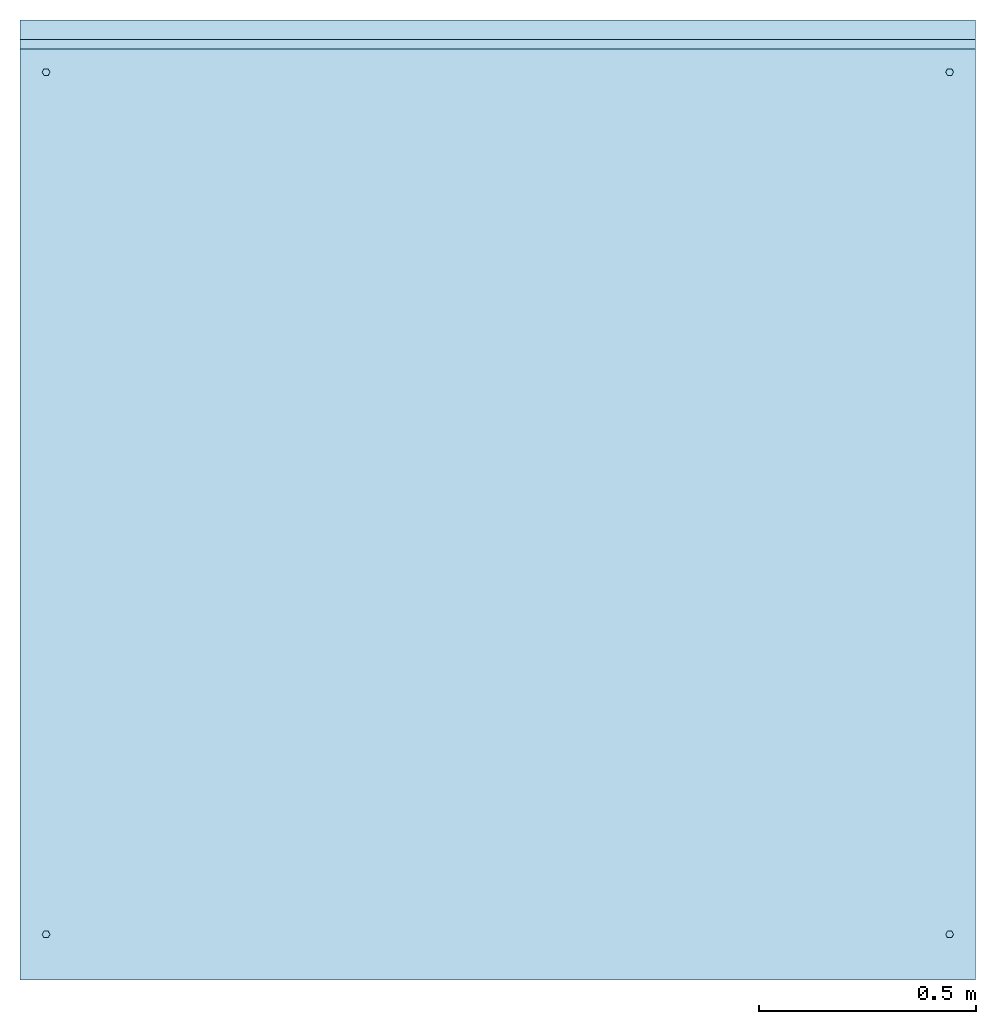
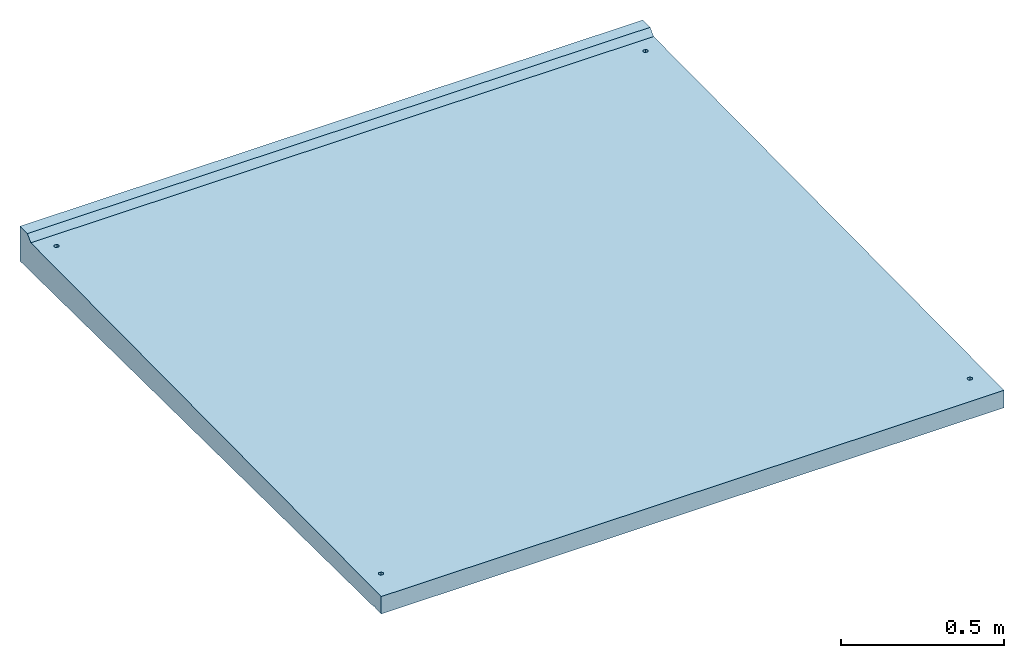
# One storey: 1 slab.
"""IFC2X3 building model written with IfcOpenShell, lengths in millimetres."""

from ifc_helpers import new_model, entity, si_unit, converted_unit, derived_unit, direction, frame, origin, place, context, subcontext, project, spatial, faceted_brep, material, type_object, element, save


model = new_model("IFC2X3")

# Units and contexts
model_context = context("Model", 3, precision=0.01, world=origin(), true_north=direction((6.12303176911189e-17, 1.0)))
body_context = subcontext(model_context, "Body", "Model", "MODEL_VIEW")
ifc_project = project(units=[si_unit("LENGTHUNIT", "METRE", prefix="MILLI"), si_unit("AREAUNIT", "SQUARE_METRE"), si_unit("VOLUMEUNIT", "CUBIC_METRE"), converted_unit("PLANEANGLEUNIT", "DEGREE", entity("IfcRatioMeasure", 0.0174532925199433), si_unit("PLANEANGLEUNIT", "RADIAN"), dimensions=[0, 0, 0, 0, 0, 0, 0]), si_unit("MASSUNIT", "GRAM", prefix="KILO"), derived_unit("MASSDENSITYUNIT", [(si_unit("MASSUNIT", "GRAM", prefix="KILO"), 1), (si_unit("LENGTHUNIT", "METRE"), -3)]), derived_unit("MOMENTOFINERTIAUNIT", [(si_unit("LENGTHUNIT", "METRE"), 4)]), si_unit("TIMEUNIT", "SECOND"), si_unit("FREQUENCYUNIT", "HERTZ"), si_unit("THERMODYNAMICTEMPERATUREUNIT", "DEGREE_CELSIUS"), derived_unit("THERMALTRANSMITTANCEUNIT", [(si_unit("MASSUNIT", "GRAM", prefix="KILO"), 1), (si_unit("THERMODYNAMICTEMPERATUREUNIT", "KELVIN"), -1), (si_unit("TIMEUNIT", "SECOND"), -3)]), derived_unit("VOLUMETRICFLOWRATEUNIT", [(si_unit("LENGTHUNIT", "METRE"), 3), (si_unit("TIMEUNIT", "SECOND"), -1)]), si_unit("ELECTRICCURRENTUNIT", "AMPERE"), si_unit("ELECTRICVOLTAGEUNIT", "VOLT"), si_unit("POWERUNIT", "WATT"), si_unit("FORCEUNIT", "NEWTON", prefix="KILO"), si_unit("ILLUMINANCEUNIT", "LUX"), si_unit("LUMINOUSFLUXUNIT", "LUMEN"), si_unit("LUMINOUSINTENSITYUNIT", "CANDELA"), derived_unit("USERDEFINED", [(si_unit("MASSUNIT", "GRAM", prefix="KILO"), -1), (si_unit("LENGTHUNIT", "METRE"), -2), (si_unit("TIMEUNIT", "SECOND"), 3), (si_unit("LUMINOUSFLUXUNIT", "LUMEN"), 1)]), derived_unit("LINEARVELOCITYUNIT", [(si_unit("LENGTHUNIT", "METRE"), 1), (si_unit("TIMEUNIT", "SECOND"), -1)]), si_unit("PRESSUREUNIT", "PASCAL"), derived_unit("USERDEFINED", [(si_unit("LENGTHUNIT", "METRE"), -2), (si_unit("MASSUNIT", "GRAM", prefix="KILO"), 1), (si_unit("TIMEUNIT", "SECOND"), -2)]), derived_unit("LINEARFORCEUNIT", [(si_unit("MASSUNIT", "GRAM", prefix="KILO"), 1), (si_unit("LENGTHUNIT", "METRE"), 1), (si_unit("TIMEUNIT", "SECOND"), -2), (si_unit("LENGTHUNIT", "METRE"), -1)]), derived_unit("PLANARFORCEUNIT", [(si_unit("MASSUNIT", "GRAM", prefix="KILO"), 1), (si_unit("LENGTHUNIT", "METRE"), 1), (si_unit("TIMEUNIT", "SECOND"), -2), (si_unit("LENGTHUNIT", "METRE"), -2)])], contexts=[model_context])

# Site, building, storey
site_placement = place(None, origin())
site = spatial("IfcSite", under=ifc_project, at=site_placement, CompositionType="ELEMENT")
building_placement = place(site_placement, origin())
building = spatial("IfcBuilding", under=site, at=building_placement, CompositionType="ELEMENT")
storey_placement = place(building_placement, origin())
storey = spatial("IfcBuildingStorey", under=building, at=storey_placement, Name="Begane Grond", CompositionType="ELEMENT", Elevation=0.0)

# Slab
ifc_material = material(Name="beton_prefab-element")
slab_type = type_object("IfcSlabType", PredefinedType="FLOOR", material=ifc_material)
slab_placement = place(storey_placement, frame((4520.21359024523, -17298.0180129677, -297.649999999983)))
element("IfcSlab", 1, at=slab_placement, inside=storey, type_object=slab_type, Name="23_GM_Standaard con R21:con, 2000x2200x65/115", PredefinedType="FLOOR", context=body_context, shape_type="Brep", body=[
    faceted_brep([(64.500000000001, 97.2057713659394, 291.110000514584), (69.0, 105.0, 291.110000514584), (64.500000000001, 112.794228634061, 291.110000514584), (55.5000000000009, 112.794228634061, 291.110000514584), (51.0, 105.0, 291.110000514584), (55.5000000000009, 97.2057713659394, 291.110000514584), (2135.5, 112.794228634061, 291.110000514584), (2131.0, 105.0, 291.110000514584), (2135.5, 97.2057713659394, 291.110000514584), (2144.5, 97.2057713659394, 291.110000514584), (2149.0, 105.0, 291.110000514584), (2144.5, 112.794228634061, 291.110000514584), (51.0, 2090.0, 310.960000514571), (55.5000000000004, 2082.20577136594, 310.960000514571), (64.5000000000005, 2082.20577136594, 310.960000514571), (69.0, 2090.0, 310.960000514571), (64.5000000000005, 2097.79422863406, 310.960000514571), (55.5000000000004, 2097.79422863406, 310.960000514571), (2131.0, 2090.0, 310.960000514571), (2135.5, 2082.20577136594, 310.960000514571), (2144.5, 2082.20577136594, 310.960000514571), (2149.0, 2090.0, 310.960000514571), (2144.5, 2097.79422863406, 310.960000514571), (2135.5, 2097.79422863406, 310.960000514571), (0.0, 2143.53535353534, 351.585353535339), (0.0, 2165.0, 373.05), (0.0, 2210.0, 373.05), (0.0, 2210.0, 243.05), (0.0, 44.9997500187486, 264.700002499813), (0.0, 42.5431741146631, 269.054911778714), (0.0, 37.5434240959141, 269.104909278902), (0.0, 35.0002499812506, 264.799997500187), (0.0, 0.0, 265.15), (0.0, 0.0, 330.15), (2200.0, 42.5431741146631, 269.054911778714), (2200.0, 44.9997500187486, 264.700002499812), (2200.0, 2210.0, 243.05), (2200.0, 2210.0, 373.05), (2200.0, 2165.0, 373.05), (2200.0, 2143.53535353534, 351.585353535339), (2200.0, 0.0, 330.15), (2200.0, 0.0, 265.15), (2200.0, 35.0002499812506, 264.799997500187), (2200.0, 37.5434240959141, 269.104909278902), (54.8874172794205, 97.5931452069559, 331.125931452069), (51.0, 105.0, 331.199999999999), (65.112582720581, 97.5931452069559, 331.125931452069), (2134.88741727942, 97.5931452069559, 331.125931452069), (2145.11258272058, 97.5931452069559, 331.125931452069), (2149.0, 105.0, 331.199999999999), (2145.11258272058, 112.406854793042, 331.27406854793), (2145.11258272058, 2082.59314520696, 350.975931452056), (2149.0, 2090.0, 351.049999999986), (2145.11258272058, 2097.40685479304, 351.124068547916), (2134.88741727942, 2097.40685479304, 351.124068547916), (54.8874172794205, 112.406854793042, 331.27406854793), (54.8874172794205, 2082.59314520696, 350.975931452056), (51.0, 2090.0, 351.049999999986), (54.8874172794205, 2097.40685479304, 351.124068547916), (65.112582720581, 2097.40685479304, 351.124068547916), (2131.0, 2090.0, 351.049999999986), (2134.88741727942, 2082.59314520696, 350.975931452056), (2134.88741727942, 112.406854793042, 331.27406854793), (65.112582720581, 112.406854793042, 331.27406854793), (65.112582720581, 2082.59314520696, 350.975931452056), (69.0, 2090.0, 351.049999999986), (2131.0, 105.0, 331.199999999999), (69.0, 105.0, 331.199999999999)], [[[0, 1, 2, 3, 4, 5]], [[6, 7, 8, 9, 10, 11]], [[12, 13, 14, 15, 16, 17]], [[18, 19, 20, 21, 22, 23]], [[24, 25, 26, 27, 28, 29, 30, 31, 32, 33]], [[34, 35, 36, 37, 38, 39, 40, 41, 42, 43]], [[33, 32, 41, 40]], [[33, 44, 45]], [[44, 33, 46]], [[33, 45, 24]], [[33, 47, 46]], [[47, 33, 40]], [[40, 48, 47]], [[48, 40, 49]], [[40, 39, 49]], [[50, 49, 39]], [[51, 50, 39]], [[52, 51, 39]], [[39, 53, 52]], [[53, 39, 54]], [[54, 39, 24]], [[45, 55, 24]], [[24, 55, 56]], [[57, 24, 56]], [[24, 57, 58]], [[24, 58, 59]], [[24, 59, 54]], [[60, 54, 59]], [[61, 50, 51]], [[62, 50, 61]], [[61, 63, 62]], [[64, 63, 61]], [[60, 64, 61]], [[55, 63, 64]], [[64, 56, 55]], [[65, 64, 60]], [[62, 63, 66]], [[63, 67, 66]], [[67, 46, 66]], [[47, 66, 46]], [[59, 65, 60]], [[27, 26, 37, 36]], [[28, 27, 36, 35]], [[32, 31, 42, 41]], [[35, 34, 29, 28]], [[34, 43, 30, 29]], [[43, 42, 31, 30]], [[25, 24, 39, 38]], [[26, 25, 38, 37]], [[44, 5, 4]], [[4, 45, 44]], [[44, 46, 0, 5]], [[47, 48, 9, 8]], [[46, 1, 0]], [[1, 46, 67]], [[63, 2, 1]], [[1, 67, 63]], [[63, 55, 3, 2]], [[50, 62, 6, 11]], [[55, 4, 3]], [[4, 55, 45]], [[47, 8, 7]], [[7, 66, 47]], [[48, 10, 9]], [[10, 48, 49]], [[50, 11, 10]], [[10, 49, 50]], [[62, 7, 6]], [[7, 62, 66]], [[56, 13, 12]], [[12, 57, 56]], [[56, 64, 14, 13]], [[61, 51, 20, 19]], [[64, 15, 14]], [[15, 64, 65]], [[59, 16, 15]], [[15, 65, 59]], [[59, 58, 17, 16]], [[53, 54, 23, 22]], [[58, 12, 17]], [[12, 58, 57]], [[61, 19, 18]], [[18, 60, 61]], [[51, 21, 20]], [[21, 51, 52]], [[53, 22, 21]], [[21, 52, 53]], [[54, 18, 23]], [[18, 54, 60]]]),
    faceted_brep([(1800.0, 2178.0, 243.37), (1800.0, 2058.0, 244.57), (1800.0, 2058.0, 0.0), (1800.0, 2178.0, 0.0), (1300.0, 2178.0, 0.0), (1300.0, 2058.0, 0.0), (1300.0, 2058.0, 244.57), (1300.0, 2178.0, 243.37), (1630.5, 2178.0, 150.473720558372), (1636.0, 2178.0, 160.0), (1619.5, 2178.0, 150.473720558372), (1480.5, 2178.0, 150.473720558372), (1469.5, 2178.0, 150.473720558372), (1464.0, 2178.0, 160.0), (1469.5, 2178.0, 169.526279441629), (1480.5, 2178.0, 169.526279441629), (1630.5, 2178.0, 169.526279441629), (1619.5, 2178.0, 169.526279441629), (1486.0, 2178.0, 160.0), (1614.0, 2178.0, 160.0), (1636.0, 2058.0, 160.0), (1630.5, 2058.0, 169.52627944163), (1619.5, 2058.0, 169.52627944163), (1480.5, 2058.0, 169.52627944163), (1469.5, 2058.0, 169.52627944163), (1464.0, 2058.0, 160.0), (1619.5, 2058.0, 150.473720558372), (1469.5, 2058.0, 150.473720558372), (1480.5, 2058.0, 150.473720558372), (1630.5, 2058.0, 150.473720558372), (1614.0, 2058.0, 160.0), (1486.0, 2058.0, 160.0)], [[[0, 1, 2, 3]], [[4, 5, 6, 7]], [[1, 0, 7, 6]], [[3, 8, 9]], [[8, 3, 10]], [[3, 4, 10]], [[9, 0, 3]], [[11, 10, 4]], [[4, 12, 11]], [[12, 4, 13]], [[7, 13, 4]], [[13, 7, 14]], [[15, 14, 7]], [[15, 7, 0]], [[0, 9, 16]], [[16, 17, 0]], [[0, 17, 15]], [[18, 15, 17]], [[19, 10, 11]], [[11, 18, 19]], [[19, 18, 17]], [[3, 2, 5, 4]], [[1, 20, 2]], [[20, 1, 21]], [[22, 21, 1]], [[1, 23, 22]], [[23, 1, 6]], [[24, 23, 6]], [[6, 25, 24]], [[25, 6, 5]], [[2, 26, 5]], [[5, 27, 25]], [[27, 5, 28]], [[28, 5, 26]], [[2, 29, 26]], [[26, 30, 28]], [[22, 31, 30]], [[31, 28, 30]], [[23, 31, 22]], [[29, 2, 20]], [[27, 12, 13, 25]], [[27, 28, 11, 12]], [[26, 29, 8, 10]], [[31, 18, 11, 28]], [[23, 15, 18, 31]], [[23, 24, 14, 15]], [[21, 22, 17, 16]], [[25, 13, 14, 24]], [[26, 10, 19, 30]], [[20, 9, 8, 29]], [[21, 16, 9, 20]], [[22, 30, 19, 17]]]),
    faceted_brep([(900.0, 2178.0, 243.37), (900.0, 2058.0, 244.57), (900.0, 2058.0, 0.0), (900.0, 2178.0, 0.0), (400.0, 2178.0, 0.0), (400.0, 2058.0, 0.0), (400.0, 2058.0, 244.57), (400.0, 2178.0, 243.37), (730.499999999999, 2178.0, 150.473720558372), (736.0, 2178.0, 160.0), (719.499999999999, 2178.0, 150.473720558372), (580.499999999999, 2178.0, 150.473720558372), (569.499999999999, 2178.0, 150.473720558372), (564.0, 2178.0, 160.0), (569.499999999999, 2178.0, 169.526279441629), (580.499999999999, 2178.0, 169.526279441629), (730.499999999999, 2178.0, 169.526279441629), (719.499999999999, 2178.0, 169.526279441629), (586.0, 2178.0, 160.0), (714.0, 2178.0, 160.0), (736.0, 2058.0, 160.0), (730.499999999999, 2058.0, 169.52627944163), (719.499999999999, 2058.0, 169.52627944163), (580.499999999999, 2058.0, 169.52627944163), (569.499999999999, 2058.0, 169.52627944163), (564.0, 2058.0, 160.0), (719.499999999999, 2058.0, 150.473720558372), (569.499999999999, 2058.0, 150.473720558372), (580.499999999999, 2058.0, 150.473720558372), (730.499999999999, 2058.0, 150.473720558372), (714.0, 2058.0, 160.0), (586.0, 2058.0, 160.0)], [[[0, 1, 2, 3]], [[4, 5, 6, 7]], [[1, 0, 7, 6]], [[3, 8, 9]], [[8, 3, 10]], [[3, 4, 10]], [[9, 0, 3]], [[11, 10, 4]], [[4, 12, 11]], [[12, 4, 13]], [[7, 13, 4]], [[13, 7, 14]], [[15, 14, 7]], [[15, 7, 0]], [[0, 9, 16]], [[16, 17, 0]], [[0, 17, 15]], [[18, 15, 17]], [[19, 10, 11]], [[11, 18, 19]], [[19, 18, 17]], [[3, 2, 5, 4]], [[1, 20, 2]], [[20, 1, 21]], [[22, 21, 1]], [[1, 23, 22]], [[23, 1, 6]], [[24, 23, 6]], [[6, 25, 24]], [[25, 6, 5]], [[2, 26, 5]], [[5, 27, 25]], [[27, 5, 28]], [[28, 5, 26]], [[2, 29, 26]], [[26, 30, 28]], [[22, 31, 30]], [[31, 28, 30]], [[23, 31, 22]], [[29, 2, 20]], [[27, 12, 13, 25]], [[27, 28, 11, 12]], [[26, 29, 8, 10]], [[31, 18, 11, 28]], [[23, 15, 18, 31]], [[23, 24, 14, 15]], [[21, 22, 17, 16]], [[25, 13, 14, 24]], [[26, 10, 19, 30]], [[20, 9, 8, 29]], [[21, 16, 9, 20]], [[22, 30, 19, 17]]]),
])

save(model, "model.ifc")
